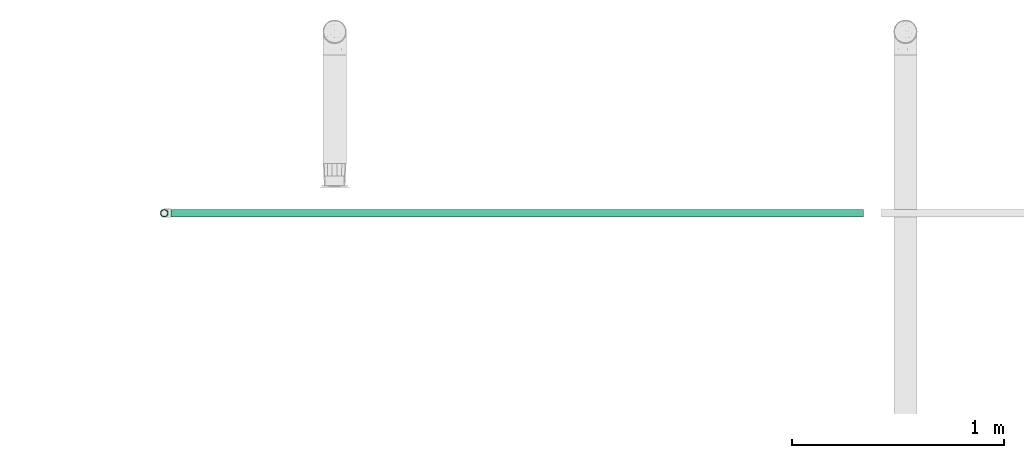
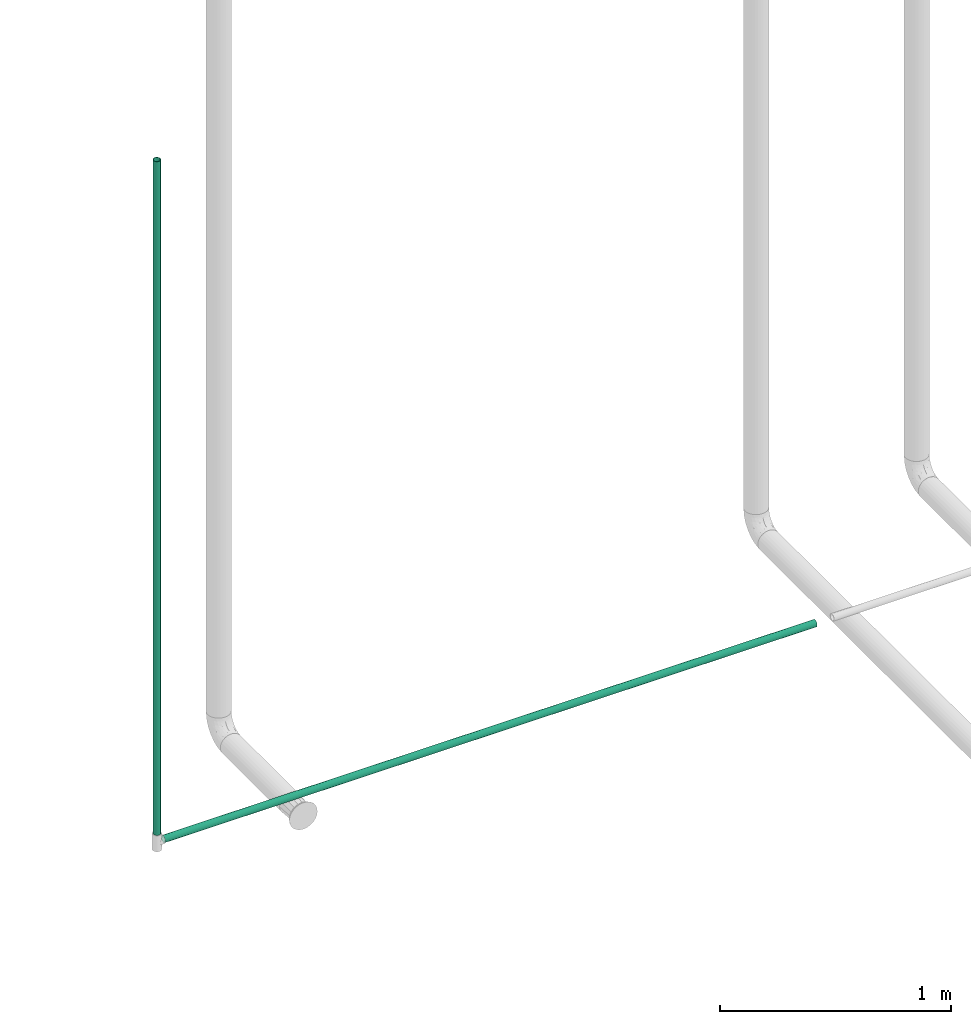
# One storey, part 8 of 123: 2 flow segments.
"""IFC2X3 building model written with IfcOpenShell, lengths in millimetres."""

import ifcopenshell
import ifcopenshell.guid

model = None  # the IFC model being written
_history = None  # IfcOwnerHistory: only IFC2X3 demands one
_inside = {}  # id of a spatial element -> (the spatial element, [elements in it])
_under = {}  # id of a project, library or spatial element -> (it, [spatial elements below it])
_declared = {}  # id of a project -> (the project, [libraries it declares])
_typed = {}  # id of a type object -> (the type object, [elements of that type])
_made_of = {}  # id of a material, layer set ... -> (it, [elements and type objects made of it])


def new_model(schema):
    """Start an empty IFC model of exactly this schema.

    Asked for "IFC4X3", IfcOpenShell would pick the latest addendum, in which some entities
    have other attributes; the version numbers below select the first issue.
    IFC2X3 requires an IfcOwnerHistory on every rooted entity: one is made here for all.
    """
    global model, _history
    if schema == "IFC4X3":
        model = ifcopenshell.file(schema_version=(4, 3, 0, 0))
    else:
        model = ifcopenshell.file(schema=schema)
    _inside.clear()
    _under.clear()
    _declared.clear()
    _typed.clear()
    _made_of.clear()
    _history = None
    if model.schema == "IFC2X3":
        org = make("IfcOrganization", Name="unknown")
        user = make(
            "IfcPersonAndOrganization",
            ThePerson=make("IfcPerson", FamilyName="unknown"),
            TheOrganization=org,
        )
        app = make(
            "IfcApplication",
            ApplicationDeveloper=org,
            Version="unknown",
            ApplicationFullName="unknown",
            ApplicationIdentifier="unknown",
        )
        _history = make(
            "IfcOwnerHistory",
            OwningUser=user,
            OwningApplication=app,
            ChangeAction="ADDED",
            CreationDate=0,
        )
    return model


def make(cls, **values):
    """One entity of the class cls with the attributes given. An attribute that is None is left unset."""
    return model.create_entity(
        cls, **{name: value for name, value in values.items() if value is not None}
    )


def entity(cls, *values):
    """Any entity or typed value of the class cls, its attributes in the order of the schema. None: left unset."""
    e = model.create_entity(cls)
    for i, value in enumerate(values):
        if value is not None:
            e[i] = value
    return e


def rooted(cls, **values):
    """An entity with a GlobalId (a new one), such as an element, a storey or a relation."""
    return make(cls, GlobalId=ifcopenshell.guid.new(), OwnerHistory=_history, **values)


def si_unit(unit_type, name, prefix=None):
    """IfcSIUnit, for example si_unit("LENGTHUNIT", "METRE", prefix="MILLI")."""
    return make("IfcSIUnit", UnitType=unit_type, Prefix=prefix, Name=name)


def converted_unit(unit_type, name, factor, base, dimensions=None, offset=None):
    """IfcConversionBasedUnit, such as the inch: factor (a typed value) times the base unit."""
    return make(
        "IfcConversionBasedUnit"
        if offset is None
        else "IfcConversionBasedUnitWithOffset",
        ConversionOffset=offset,
        Dimensions=None
        if dimensions is None
        else entity("IfcDimensionalExponents", *dimensions),
        UnitType=unit_type,
        Name=name,
        ConversionFactor=make(
            "IfcMeasureWithUnit", ValueComponent=factor, UnitComponent=base
        ),
    )


def derived_unit(unit_type, elements):
    """IfcDerivedUnit: a product of units, each with its exponent."""
    return make(
        "IfcDerivedUnit",
        Elements=[
            make("IfcDerivedUnitElement", Unit=unit, Exponent=power)
            for unit, power in elements
        ],
        UnitType=unit_type,
    )


def assignment(units):
    """IfcUnitAssignment: the units of a project."""
    return None if units is None else make("IfcUnitAssignment", Units=units)


def point(xyz):
    """IfcCartesianPoint."""
    return None if xyz is None else make("IfcCartesianPoint", Coordinates=xyz)


def direction(xyz):
    """IfcDirection."""
    return None if xyz is None else make("IfcDirection", DirectionRatios=xyz)


def frame(location, z_axis=None, x_axis=None):
    """IfcAxis2Placement3D, a coordinate frame: its origin and axes. An axis left out is left unset."""
    return make(
        "IfcAxis2Placement3D",
        Location=point(location),
        Axis=direction(z_axis),
        RefDirection=direction(x_axis),
    )


def frame_2d(location, x_axis=None):
    """IfcAxis2Placement2D, a coordinate frame in the plane: its origin and x axis."""
    return make(
        "IfcAxis2Placement2D", Location=point(location), RefDirection=direction(x_axis)
    )


def origin_with_axes():
    """The frame at (0, 0, 0) with the z axis (0, 0, 1) and the x axis (1, 0, 0) written out."""
    return frame((0.0, 0.0, 0.0), z_axis=(0.0, 0.0, 1.0), x_axis=(1.0, 0.0, 0.0))


def origin_2d_with_axis():
    """The frame at (0, 0) in the plane with the x axis (1, 0) written out."""
    return frame_2d((0.0, 0.0), x_axis=(1.0, 0.0))


def place(relative_to, where):
    """IfcLocalPlacement: puts the frame where relative to a parent placement (None: the world)."""
    return make(
        "IfcLocalPlacement", PlacementRelTo=relative_to, RelativePlacement=where
    )


def context(
    kind, dimensions, precision=None, world=None, true_north=None, identifier=None
):
    """IfcGeometricRepresentationContext, for example the 3D "Model" context."""
    return make(
        "IfcGeometricRepresentationContext",
        ContextIdentifier=identifier,
        ContextType=kind,
        CoordinateSpaceDimension=dimensions,
        Precision=precision,
        WorldCoordinateSystem=world,
        TrueNorth=true_north,
    )


def subcontext(parent, identifier, kind, view, scale=None):
    """IfcGeometricRepresentationSubContext, for example "Body" below "Model"."""
    return make(
        "IfcGeometricRepresentationSubContext",
        ContextIdentifier=identifier,
        ContextType=kind,
        ParentContext=parent,
        TargetScale=scale,
        TargetView=view,
    )


def project(units=None, contexts=None):
    """IfcProject with its units and contexts."""
    return rooted(
        "IfcProject",
        Name="project",
        RepresentationContexts=contexts,
        UnitsInContext=assignment(units),
    )


def spatial(cls, under=None, at=None, **own):
    """A site, building, storey or space (cls), placed at a placement, below another one or the project."""
    s = rooted(cls, ObjectPlacement=at, **own)
    if under is not None:
        _under.setdefault(under.id(), (under, []))[1].append(s)
    return s


def profile(cls, at=None, kind="AREA", **sizes):
    """A parametric profile (cls). Its sizes go by their IFC names, for example OverallWidth=200.0."""
    return make(cls, ProfileType=kind, Position=at, **sizes)


def hollow_circle(**sizes):
    """IfcCircleHollowProfileDef."""
    return profile("IfcCircleHollowProfileDef", **sizes)


def extrude(swept, where, along, depth):
    """IfcExtrudedAreaSolid: the profile swept, set in the frame where, extruded along a direction by depth."""
    return make(
        "IfcExtrudedAreaSolid",
        SweptArea=swept,
        Position=where,
        ExtrudedDirection=direction(along),
        Depth=depth,
    )


def shape(context_of_items, identifier, shape_type, items):
    """IfcShapeRepresentation: the items that make up one representation, for example the "Body"."""
    return make(
        "IfcShapeRepresentation",
        ContextOfItems=context_of_items,
        RepresentationIdentifier=identifier,
        RepresentationType=shape_type,
        Items=items,
    )


def source(mapping_origin, context_of_items, identifier, shape_type, items):
    """IfcRepresentationMap: a shape defined once, which mapped items show again and again."""
    return make(
        "IfcRepresentationMap",
        MappingOrigin=mapping_origin,
        MappedRepresentation=shape(context_of_items, identifier, shape_type, items),
    )


def transform(
    local_origin,
    x_axis=None,
    y_axis=None,
    z_axis=None,
    scale=None,
    scale2=None,
    scale3=None,
    uniform=True,
):
    """IfcCartesianTransformationOperator3D, or its non-uniform kind. x_axis, y_axis, z_axis: its Axis1, 2, 3."""
    if uniform:
        return make(
            "IfcCartesianTransformationOperator3D",
            Axis1=direction(x_axis),
            Axis2=direction(y_axis),
            LocalOrigin=point(local_origin),
            Scale=scale,
            Axis3=direction(z_axis),
        )
    return make(
        "IfcCartesianTransformationOperator3DnonUniform",
        Axis1=direction(x_axis),
        Axis2=direction(y_axis),
        LocalOrigin=point(local_origin),
        Scale=scale,
        Axis3=direction(z_axis),
        Scale2=scale2,
        Scale3=scale3,
    )


def mapped(mapping_source, mapping_target):
    """IfcMappedItem: shows the shape of a source again, moved by a transform."""
    return make(
        "IfcMappedItem", MappingSource=mapping_source, MappingTarget=mapping_target
    )


def material(Name=None, Category=None):
    """IfcMaterial."""
    return make("IfcMaterial", Name=Name, Category=Category)


def layer(
    of_material, thickness, ventilated=None, Name=None, Category=None, Priority=None
):
    """IfcMaterialLayer: one layer of a wall or slab, of a material (None: an air gap)."""
    return make(
        "IfcMaterialLayer",
        Material=of_material,
        LayerThickness=thickness,
        IsVentilated=ventilated,
        Name=Name,
        Category=Category,
        Priority=Priority,
    )


def layer_set(layers, Name=None):
    """IfcMaterialLayerSet."""
    return make("IfcMaterialLayerSet", MaterialLayers=layers, LayerSetName=Name)


def layer_usage(for_layer_set, set_direction, sense, offset, extent=None):
    """IfcMaterialLayerSetUsage: how a layer set lies in its element."""
    return make(
        "IfcMaterialLayerSetUsage",
        ForLayerSet=for_layer_set,
        LayerSetDirection=set_direction,
        DirectionSense=sense,
        OffsetFromReferenceLine=offset,
        ReferenceExtent=extent,
    )


def made_of(thing, what):
    """Note that an element or type object is made of a material, layer set ...; save() writes the relation."""
    if what is not None:
        _made_of.setdefault(what.id(), (what, []))[1].append(thing)
    return thing


def type_object(cls, material=None, **own):
    """A type object (cls), such as IfcWallType, which elements share."""
    return made_of(rooted(cls, **own), material)


def element(
    cls,
    number,
    at=None,
    inside=None,
    cuts=None,
    type_object=None,
    material=None,
    context=None,
    identifier="Body",
    shape_type=None,
    held_by="IfcProductDefinitionShape",
    body=None,
    shapes=None,
    **own,
):
    """One element of the class cls, such as IfcWall. Its Tag is "e" and its number.

    at: its placement. inside: the storey or other place that contains it. cuts: it is an
    opening in that element (IfcRelVoidsElement). A single representation is given by context,
    identifier, shape_type and body (its items); several are given by shapes. held_by: the class
    of the entity that holds the representations. save() writes the other relations.
    """
    e = rooted(cls, Tag="e%d" % number, ObjectPlacement=at, **own)
    if body is not None:
        shapes = [shape(context, identifier, shape_type, body)]
    if shapes is not None:
        e.Representation = make(held_by, Representations=shapes)
    if inside is not None:
        _inside.setdefault(inside.id(), (inside, []))[1].append(e)
    if cuts is not None:
        rooted(
            "IfcRelVoidsElement", RelatingBuildingElement=cuts, RelatedOpeningElement=e
        )
    if type_object is not None:
        _typed.setdefault(type_object.id(), (type_object, []))[1].append(e)
    return made_of(e, material)


def aggregate(whole, parts):
    """IfcRelAggregates: a whole, such as a stair, and the parts it consists of."""
    return rooted("IfcRelAggregates", RelatingObject=whole, RelatedObjects=parts)


def save(model, path):
    """Write the relations noted so far, then the file.

    IfcRelAggregates (storeys below a building ...), IfcRelContainedInSpatialStructure (elements
    in a storey), IfcRelDefinesByType, IfcRelAssociatesMaterial and IfcRelDeclares: one each for
    every whole, place, type object, material and project.
    """
    for whole, parts in _under.values():
        aggregate(whole, parts)
    for where, things in _inside.values():
        rooted(
            "IfcRelContainedInSpatialStructure",
            RelatedElements=things,
            RelatingStructure=where,
        )
    for kind, things in _typed.values():
        rooted("IfcRelDefinesByType", RelatedObjects=things, RelatingType=kind)
    for what, things in _made_of.values():
        rooted("IfcRelAssociatesMaterial", RelatedObjects=things, RelatingMaterial=what)
    for by, libraries in _declared.values():
        rooted("IfcRelDeclares", RelatingContext=by, RelatedDefinitions=libraries)
    model.write(path)


model = new_model("IFC2X3")

# Units and contexts
model_context = context("Model", 3, precision=1e-05, world=origin_with_axes(), true_north=direction((0.0, 1.0)))
body_context = subcontext(model_context, "Body", "Model", "MODEL_VIEW")
ifc_project = project(units=[si_unit("AREAUNIT", "SQUARE_METRE"), si_unit("VOLUMEUNIT", "CUBIC_METRE", prefix="DECI"), si_unit("TIMEUNIT", "SECOND"), si_unit("THERMODYNAMICTEMPERATUREUNIT", "DEGREE_CELSIUS"), si_unit("PRESSUREUNIT", "PASCAL"), si_unit("MASSUNIT", "GRAM", prefix="KILO"), si_unit("LENGTHUNIT", "METRE", prefix="MILLI"), si_unit("POWERUNIT", "WATT"), si_unit("ELECTRICCURRENTUNIT", "AMPERE"), si_unit("ELECTRICVOLTAGEUNIT", "VOLT"), derived_unit("VOLUMETRICFLOWRATEUNIT", [(si_unit("VOLUMEUNIT", "CUBIC_METRE", prefix="DECI"), 1), (si_unit("TIMEUNIT", "SECOND"), -1)]), derived_unit("LINEARVELOCITYUNIT", [(si_unit("LENGTHUNIT", "METRE"), 1), (si_unit("TIMEUNIT", "SECOND"), -1)]), derived_unit("MASSDENSITYUNIT", [(si_unit("MASSUNIT", "GRAM", prefix="KILO"), 1), (si_unit("VOLUMEUNIT", "CUBIC_METRE"), -1)]), converted_unit("PLANEANGLEUNIT", "DEGREE", entity("IfcRatioMeasure", 0.01745), si_unit("PLANEANGLEUNIT", "RADIAN"), dimensions=[0, 0, 0, 0, 0, 0, 0])], contexts=[model_context])

# Site, building, storey
site_placement = place(None, origin_with_axes())
site = spatial("IfcSite", under=ifc_project, at=site_placement, CompositionType="ELEMENT")
building_placement = place(site_placement, origin_with_axes())
building = spatial("IfcBuilding", under=site, at=building_placement, Name="mc-building", CompositionType="ELEMENT")
storey_placement = place(building_placement, origin_with_axes())
storey = spatial("IfcBuildingStorey", under=building, at=storey_placement, Name="1. Korrus", CompositionType="ELEMENT", Elevation=0.0)

# Flow segments
ifc_material = material(Name="Steel")
ifc_layer = layer(ifc_material, 0.0)
ifc_layer_set = layer_set([ifc_layer], Name="Steel")
ifc_layer_usage = layer_usage(ifc_layer_set, "AXIS1", "POSITIVE", 0.0)
pipe_segment_type = type_object("IfcPipeSegmentType", PredefinedType="RIGIDSEGMENT")
shared_shape_1 = source(origin_with_axes(), body_context, "Body", "SweptSolid", [
    extrude(hollow_circle(Radius=17.5, WallThickness=2.0, at=origin_2d_with_axis()), frame((0.0, 0.0, 0.0), z_axis=(1.0, 0.0, 0.0), x_axis=(0.0, 1.0, 0.0)), (0.0, 0.0, 1.0), 3263.7),
])
flow_segment_1_placement = place(storey_placement, frame((14781.04018, 12807.91734, 2520.89768), z_axis=(0.0, 0.0, 1.0), x_axis=(1.0, 0.0, 0.0)))
element("IfcFlowSegment", 1, at=flow_segment_1_placement, inside=storey, type_object=pipe_segment_type, material=ifc_layer_usage, context=body_context, shape_type="MappedRepresentation", body=[
    mapped(shared_shape_1, transform((0.0, 0.0, 0.0), scale=1.0)),
])
shared_shape_2 = source(origin_with_axes(), body_context, "Body", "SweptSolid", [
    extrude(hollow_circle(Radius=17.5, WallThickness=2.0, at=origin_2d_with_axis()), frame((0.0, 0.0, 0.0), z_axis=(1.0, 0.0, 0.0), x_axis=(0.0, 1.0, 0.0)), (0.0, 0.0, 1.0), 3565.0),
])
flow_segment_2_placement = place(storey_placement, frame((14749.24018, 12807.91734, 2563.29768), z_axis=(-1.0, 0.0, 0.0), x_axis=(0.0, 0.0, 1.0)))
element("IfcFlowSegment", 2, at=flow_segment_2_placement, inside=storey, type_object=pipe_segment_type, material=ifc_layer_usage, context=body_context, shape_type="MappedRepresentation", body=[
    mapped(shared_shape_2, transform((0.0, 0.0, 0.0), scale=1.0)),
])

save(model, "model.ifc")
